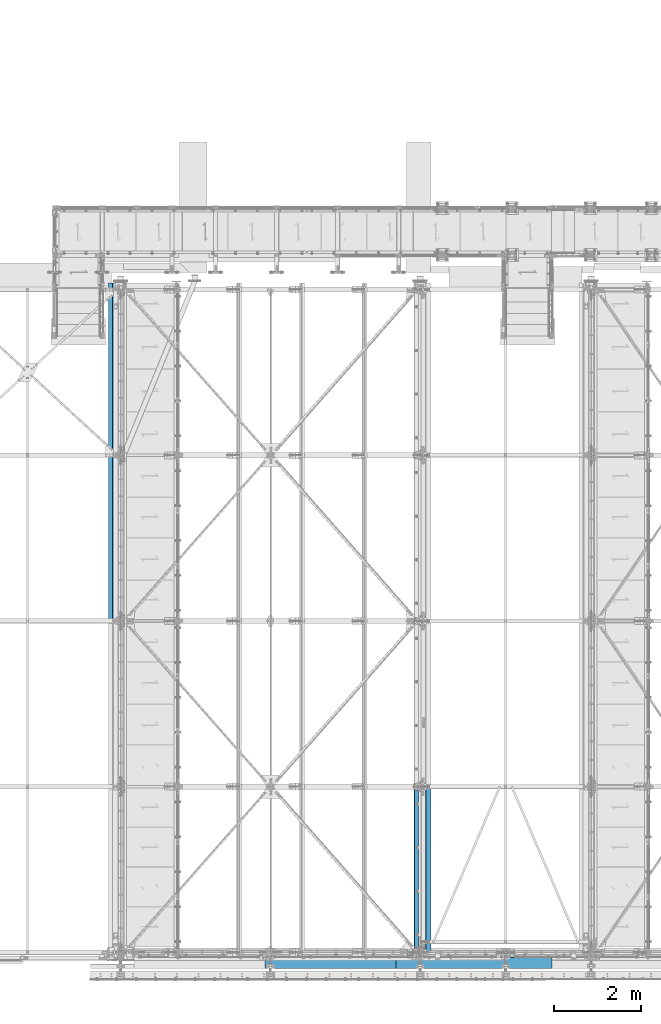
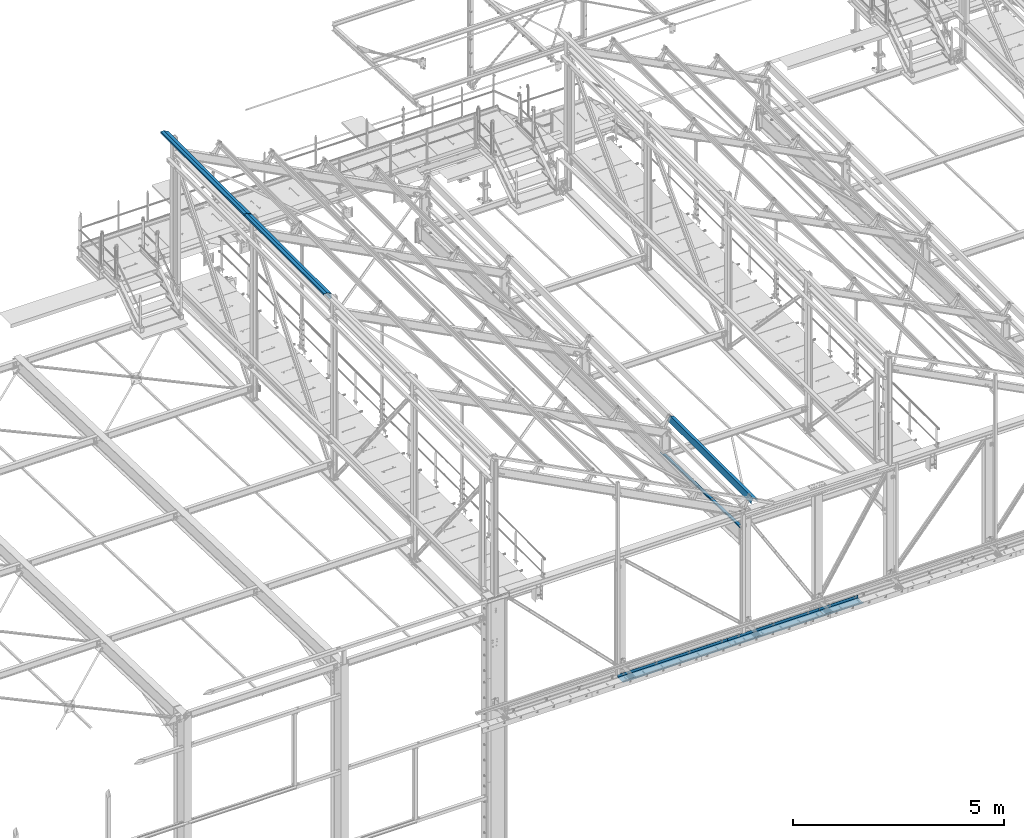
# One storey, part 346 of 496: 7 beams, 7 elements without a shape of their own.
"""IFC2X3 building model written with IfcOpenShell, lengths in millimetres."""

from ifc_helpers import new_model, si_unit, frame, origin_with_axes, place, context, subcontext, project, spatial, faceted_brep, material, type_object, element, aggregate, save


model = new_model("IFC2X3")

# Units and contexts
model_context = context("Model", 3, precision=1e-05, world=origin_with_axes())
body_context = subcontext(model_context, "Body", "Model", "MODEL_VIEW")
ifc_project = project(units=[si_unit("LENGTHUNIT", "METRE", prefix="MILLI"), si_unit("AREAUNIT", "SQUARE_METRE"), si_unit("VOLUMEUNIT", "CUBIC_METRE"), si_unit("MASSUNIT", "GRAM", prefix="KILO"), si_unit("TIMEUNIT", "SECOND"), si_unit("PLANEANGLEUNIT", "RADIAN"), si_unit("SOLIDANGLEUNIT", "STERADIAN"), si_unit("THERMODYNAMICTEMPERATUREUNIT", "DEGREE_CELSIUS"), si_unit("LUMINOUSINTENSITYUNIT", "LUMEN")], contexts=[model_context])

# Site, building, storey
site_placement = place(None, origin_with_axes())
site = spatial("IfcSite", under=ifc_project, at=site_placement, CompositionType="ELEMENT")
building_placement = place(site_placement, origin_with_axes())
building = spatial("IfcBuilding", under=site, at=building_placement, Name="Undefined", CompositionType="ELEMENT")
storey_placement = place(building_placement, origin_with_axes())
storey = spatial("IfcBuildingStorey", under=building, at=storey_placement, Name="Undefined", CompositionType="ELEMENT", Elevation=0.0)

# Assembly, beam
assembly_1_placement = place(storey_placement, origin_with_axes())
assembly_1 = element("IfcElementAssembly", 1, at=assembly_1_placement, inside=storey, Name="SHED", AssemblyPlace="NOTDEFINED", PredefinedType="NOTDEFINED")
ifc_material = material(Name="Undefined/S235-E24")
beam_type_1 = type_object("IfcBeamType", PredefinedType="NOTDEFINED")
beam_1_placement = place(assembly_1_placement, frame((12404.99999895, 9499.99999584194, 12628.7260697614), z_axis=(0.0, 1.0, 0.0), x_axis=(0.0, 0.0, 1.0)))
beam_1 = element("IfcBeam", 2, at=beam_1_placement, type_object=beam_type_1, material=ifc_material, Name="SHED", context=body_context, shape_type="Brep", body=[
    faceted_brep([(-3.49427864421159e-08, -1.49999999999636, -1895.0), (-3.52956703864038e-08, -1.5, 1895.0), (3.49573383573443e-08, 1.5, 1895.0), (3.53102223016322e-08, 1.5, -1895.0), (47.0000011861484, 1.499998899395, 1895.0), (47.0000011898519, 1.49999889939863, -1895.0), (50.0000011927114, -1.50000117085074, -1895.0), (50.0000011890152, -1.50000117085438, 1895.0), (47.0, 83.711228987213, 1895.0), (47.0, 83.711228987213, -1895.0), (50.0, 84.4485168457013, -1895.0), (50.0, 84.4485168457013, 1895.0), (-16.7103107286657, 205.5, 1895.0), (-16.7103107286657, 205.5, -1895.0), (-14.8939838409424, 208.5, -1895.0), (-14.8939838409424, 208.5, 1895.0), (-151.893997192383, 205.5, 1895.0), (-151.893997192383, 205.5, -1895.0), (-154.893997192383, 208.5, -1895.0), (-154.893997192383, 208.5, 1895.0), (-151.893997192383, 158.5, 1895.0), (-151.893997192383, 158.5, -1895.0), (-154.893997192383, 158.5, 1895.0), (-154.893997192383, 158.5, -1895.0)], [[[0, 1, 2, 3]], [[3, 2, 4, 5]], [[1, 0, 6, 7]], [[5, 4, 8, 9]], [[7, 6, 10, 11]], [[9, 8, 12, 13]], [[11, 10, 14, 15]], [[13, 12, 16, 17]], [[15, 14, 18, 19]], [[17, 16, 20, 21]], [[16, 12, 8, 4, 2, 1, 7, 11, 15, 19, 22, 20]], [[19, 18, 23, 22]], [[18, 14, 10, 6, 0, 3, 5, 9, 13, 17, 21, 23]], [[22, 23, 21, 20]]]),
])
aggregate(assembly_1, [beam_1])

assembly_2_placement = place(storey_placement, origin_with_axes())
assembly_2 = element("IfcElementAssembly", 3, at=assembly_2_placement, inside=storey, Name="SUPPORT", AssemblyPlace="NOTDEFINED", PredefinedType="NOTDEFINED")
beam_type_2 = type_object("IfcBeamType", PredefinedType="NOTDEFINED")
beam_2_placement = place(assembly_2_placement, frame((22042.5, -111.5, 5080.00085614788), z_axis=(1.0, 0.0, 0.0), x_axis=(0.0, 0.0, -1.0)))
beam_2 = element("IfcBeam", 4, at=beam_2_placement, type_object=beam_type_2, material=ifc_material, Name="SUPPORT", context=body_context, shape_type="Brep", body=[
    faceted_brep([(0.0, -1.5, -527.5), (0.0, -1.5, 527.5), (0.0, 1.5, 527.5), (0.0, 1.5, -527.5), (80.0, 1.5, 527.5), (80.0, 1.5, -527.5), (77.0, -1.5, -527.5), (77.0, -1.5, 527.5), (80.0, -258.5, 527.5), (80.0, -258.5, -527.5), (77.0, -255.5, -527.5), (77.0, -255.5, 527.5), (30.0000019073486, -258.5, 527.5), (30.0000019073486, -258.5, -527.5), (30.0000019073486, -255.5, 527.5), (30.0000019073486, -255.5, -527.5)], [[[0, 1, 2, 3]], [[3, 2, 4, 5]], [[1, 0, 6, 7]], [[5, 4, 8, 9]], [[7, 6, 10, 11]], [[9, 8, 12, 13]], [[8, 4, 2, 1, 7, 11, 14, 12]], [[11, 10, 15, 14]], [[10, 6, 0, 3, 5, 9, 13, 15]], [[14, 15, 13, 12]]]),
])
aggregate(assembly_2, [beam_2])

assembly_3_placement = place(storey_placement, origin_with_axes())
assembly_3 = element("IfcElementAssembly", 5, at=assembly_3_placement, inside=storey, Name="SUPPORT", AssemblyPlace="NOTDEFINED", PredefinedType="NOTDEFINED")
beam_type_3 = type_object("IfcBeamType", PredefinedType="NOTDEFINED")
beam_3_placement = place(assembly_3_placement, frame((17489.9999999585, -111.5, 5080.00085614788), z_axis=(1.0, 0.0, 0.0), x_axis=(0.0, 0.0, -1.0)))
beam_3 = element("IfcBeam", 6, at=beam_3_placement, type_object=beam_type_3, material=ifc_material, Name="SUPPORT", context=body_context, shape_type="Brep", body=[
    faceted_brep([(0.0, -1.5, -1500.0), (0.0, -1.5, 1500.0), (0.0, 1.5, 1500.0), (0.0, 1.5, -1500.0), (80.0, 1.5, 1500.0), (80.0, 1.5, -1500.0), (77.0, -1.5, -1500.0), (77.0, -1.5, 1500.0), (80.0, -258.5, 1500.0), (80.0, -258.5, -1500.0), (77.0, -255.5, -1500.0), (77.0, -255.5, 1500.0), (30.0000019073486, -258.5, 1500.0), (30.0000019073486, -258.5, -1500.0), (30.0000019073486, -255.5, 1500.0), (30.0000019073486, -255.5, -1500.0)], [[[0, 1, 2, 3]], [[3, 2, 4, 5]], [[1, 0, 6, 7]], [[5, 4, 8, 9]], [[7, 6, 10, 11]], [[9, 8, 12, 13]], [[8, 4, 2, 1, 7, 11, 14, 12]], [[11, 10, 15, 14]], [[10, 6, 0, 3, 5, 9, 13, 15]], [[14, 15, 13, 12]]]),
])
aggregate(assembly_3, [beam_3])

assembly_4_placement = place(storey_placement, origin_with_axes())
assembly_4 = element("IfcElementAssembly", 7, at=assembly_4_placement, inside=storey, Name="SUPPORT", AssemblyPlace="NOTDEFINED", PredefinedType="NOTDEFINED")
beam_type_4 = type_object("IfcBeamType", PredefinedType="NOTDEFINED")
beam_4_placement = place(assembly_4_placement, frame((20247.4999999585, -111.5, 5080.00085614788), z_axis=(1.0, 0.0, 0.0), x_axis=(0.0, 0.0, -1.0)))
beam_4 = element("IfcBeam", 8, at=beam_4_placement, type_object=beam_type_4, material=ifc_material, Name="SUPPORT", context=body_context, shape_type="Brep", body=[
    faceted_brep([(0.0, -1.5, -1257.5), (0.0, -1.5, 1257.5), (0.0, 1.5, 1257.5), (0.0, 1.5, -1257.5), (80.0, 1.5, 1257.5), (80.0, 1.5, -1257.5), (77.0, -1.5, -1257.5), (77.0, -1.5, 1257.5), (80.0, -258.5, 1257.5), (80.0, -258.5, -1257.5), (77.0, -255.5, -1257.5), (77.0, -255.5, 1257.5), (30.0000019073486, -258.5, 1257.5), (30.0000019073486, -258.5, -1257.5), (30.0000019073486, -255.5, 1257.5), (30.0000019073486, -255.5, -1257.5)], [[[0, 1, 2, 3]], [[3, 2, 4, 5]], [[1, 0, 6, 7]], [[5, 4, 8, 9]], [[7, 6, 10, 11]], [[9, 8, 12, 13]], [[8, 4, 2, 1, 7, 11, 14, 12]], [[11, 10, 15, 14]], [[10, 6, 0, 3, 5, 9, 13, 15]], [[14, 15, 13, 12]]]),
])
aggregate(assembly_4, [beam_4])

assembly_5_placement = place(storey_placement, origin_with_axes())
assembly_5 = element("IfcElementAssembly", 9, at=assembly_5_placement, inside=storey, Name="POUTRE", AssemblyPlace="NOTDEFINED", PredefinedType="NOTDEFINED")
beam_type_5 = type_object("IfcBeamType", PredefinedType="NOTDEFINED")
beam_5_placement = place(assembly_5_placement, frame((19509.9999999999, 1899.71695009892, 7991.29997216438), z_axis=(0.0, 0.999506556345274, -0.0314108870109058), x_axis=(-1.0, 0.0, 0.0)))
beam_5 = element("IfcBeam", 10, at=beam_5_placement, type_object=beam_type_5, material=ifc_material, Name="POUTRE", context=body_context, shape_type="Brep", body=[
    faceted_brep([(84.9999999979264, 0.999999999923602, 1895.93800542073), (84.9999999999563, 0.999999999923602, 1815.93800543636), (84.9999999999563, -1.00000000007185, 1815.93800543636), (84.9999999979264, -1.00000000007731, 1895.93800542073), (7.27595761418343e-12, 1.00000000000182, 1815.93800543633), (0.0, -0.999999999999091, 1815.93800543633), (97.9999999997781, 39.0000003423347, -1895.93800544557), (97.9999999997708, 0.999999999877218, -1895.93800544559), (97.9999999997854, 0.999999999877218, 1895.93800542178), (97.9999999997781, 39.0000003423356, 1895.9380054218), (99.9999999997781, 39.0000003423347, -1895.93800544557), (99.9999999997781, 39.0000003423356, 1895.9380054218), (99.9999999997708, -1.00000000012551, -1895.93800544559), (99.9999999997854, -1.0000000001246, 1895.93800542178), (85.0000000000728, -1.00000000007822, -1895.93800544091), (85.0000000000728, 0.999999999920874, -1895.9380054409), (84.9999999999163, -1.00000000010914, -1775.9380054101), (84.9999999999163, 0.999999999896318, -1775.93800948012), (0.0, 1.00000000000091, -1775.93800948012), (-3.63797880709171e-12, -1.0, -1775.9380054101)], [[[0, 1, 2, 3]], [[4, 5, 2, 1]], [[6, 7, 8, 9]], [[10, 6, 9, 11]], [[12, 10, 11, 13]], [[7, 6, 10, 12, 14, 15]], [[15, 14, 16, 17]], [[18, 17, 16, 19]], [[0, 8, 7, 15, 17, 18, 4, 1]], [[13, 11, 9, 8, 0, 3]], [[19, 16, 14, 12, 13, 3, 2, 5]], [[18, 19, 5, 4]]]),
])
aggregate(assembly_5, [beam_5])

assembly_6_placement = place(storey_placement, origin_with_axes())
assembly_6 = element("IfcElementAssembly", 11, at=assembly_6_placement, inside=storey, Name="SHED", AssemblyPlace="NOTDEFINED", PredefinedType="NOTDEFINED")
beam_type_6 = type_object("IfcBeamType", PredefinedType="NOTDEFINED")
beam_6_placement = place(assembly_6_placement, frame((19656.0539262703, 1820.00010459345, 8773.41543702207), z_axis=(0.0, 1.0, 0.0), x_axis=(-0.886081824994261, -1.3000000762986e-08, 0.46352885499701)))
beam_6 = element("IfcBeam", 12, at=beam_6_placement, type_object=beam_type_6, material=ifc_material, Name="SHED", context=body_context, shape_type="Brep", body=[
    faceted_brep([(-4.57293936051428e-09, -1.5, -1975.0), (-2.82670953311026e-09, -1.49999999999636, 1975.0), (4.57293936051428e-09, 1.50000000000364, 1975.0), (2.82307155430317e-09, 1.50000000000364, -1975.0), (46.9999982244844, 1.49999988410855, 1974.99999999998), (46.9999982243717, 1.49999988410491, -1975.00000000002), (49.9999982228783, -1.50000012329474, -1975.00000000002), (49.9999982229929, -1.5000001232911, 1974.99999999998), (46.9999982920745, 135.499998582192, 1975.00000000004), (46.9999982902773, 135.499998584666, -1974.99999999997), (49.9999982917725, 138.499998490119, -1974.99999999997), (49.9999982935697, 138.499998487649, 1975.00000000004), (-88.1836776470518, 135.500002842877, 1975.00000000013), (-88.1836776506552, 135.500002844674, -1974.99999999987), (-90.0000045074175, 138.500002901914, -1974.99999999987), (-90.0000045038087, 138.50000290012, 1975.00000000013), (-124.424035514894, 66.2228546089173, 1975.00000000015), (-124.424035518259, 66.2228546094775, -1974.99999999985), (-127.082281608138, 67.6134399920447, 1975.00000000015), (-127.0822816115, 67.6134399926013, -1974.99999999985)], [[[0, 1, 2, 3]], [[3, 2, 4, 5]], [[1, 0, 6, 7]], [[5, 4, 8, 9]], [[7, 6, 10, 11]], [[9, 8, 12, 13]], [[11, 10, 14, 15]], [[13, 12, 16, 17]], [[12, 8, 4, 2, 1, 7, 11, 15, 18, 16]], [[15, 14, 19, 18]], [[14, 10, 6, 0, 3, 5, 9, 13, 17, 19]], [[18, 19, 17, 16]]]),
])
aggregate(assembly_6, [beam_6])

assembly_7_placement = place(storey_placement, origin_with_axes())
assembly_7 = element("IfcElementAssembly", 13, at=assembly_7_placement, inside=storey, Name="SHED", AssemblyPlace="NOTDEFINED", PredefinedType="NOTDEFINED")
beam_7_placement = place(assembly_7_placement, frame((12404.99999895, 13379.9999958419, 12628.7260697583), z_axis=(0.0, 1.0, 0.0), x_axis=(0.0, 0.0, 1.0)))
beam_7 = element("IfcBeam", 14, at=beam_7_placement, type_object=beam_type_6, material=ifc_material, Name="SHED", context=body_context, shape_type="Brep", body=[
    faceted_brep([(-4.57293936051428e-09, -1.5, -1975.0), (-2.82670953311026e-09, -1.49999999999636, 1975.0), (4.57293936051428e-09, 1.50000000000364, 1975.0), (2.82307155430317e-09, 1.50000000000364, -1975.0), (46.9999982244844, 1.49999988410855, 1974.99999999998), (46.9999982243717, 1.49999988410491, -1975.00000000002), (49.9999982228783, -1.50000012329474, -1975.00000000002), (49.9999982229929, -1.5000001232911, 1974.99999999998), (47.0, 83.711228987213, 1975.0), (47.0, 83.711228987213, -1975.0), (50.0, 84.4485168457013, -1975.0), (50.0, 84.4485168457013, 1975.0), (-16.7103107286657, 205.5, 1975.0), (-16.7103107286657, 205.5, -1975.0), (-14.8939838409424, 208.5, -1975.0), (-14.8939838409424, 208.5, 1975.0), (-151.893997192383, 205.5, 1975.0), (-151.893997192383, 205.5, -1975.0), (-154.893997192383, 208.5, -1975.0), (-154.893997192383, 208.5, 1975.0), (-151.893997192383, 158.5, 1975.0), (-151.893997192383, 158.5, -1975.0), (-154.893997192383, 158.5, 1975.0), (-154.893997192383, 158.5, -1975.0)], [[[0, 1, 2, 3]], [[3, 2, 4, 5]], [[1, 0, 6, 7]], [[5, 4, 8, 9]], [[7, 6, 10, 11]], [[9, 8, 12, 13]], [[11, 10, 14, 15]], [[13, 12, 16, 17]], [[15, 14, 18, 19]], [[17, 16, 20, 21]], [[16, 12, 8, 4, 2, 1, 7, 11, 15, 19, 22, 20]], [[19, 18, 23, 22]], [[18, 14, 10, 6, 0, 3, 5, 9, 13, 17, 21, 23]], [[22, 23, 21, 20]]]),
])
aggregate(assembly_7, [beam_7])

save(model, "model.ifc")
